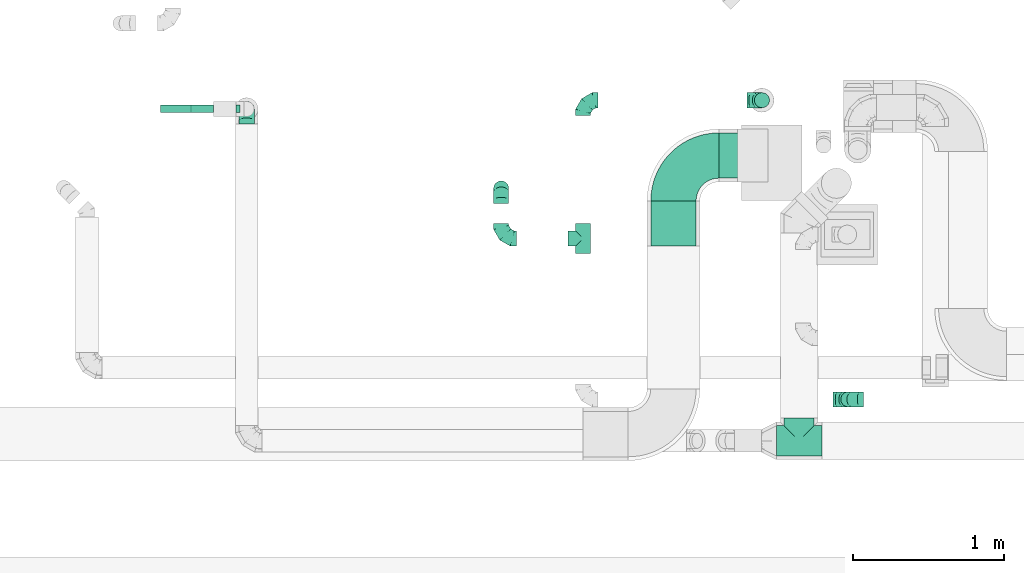
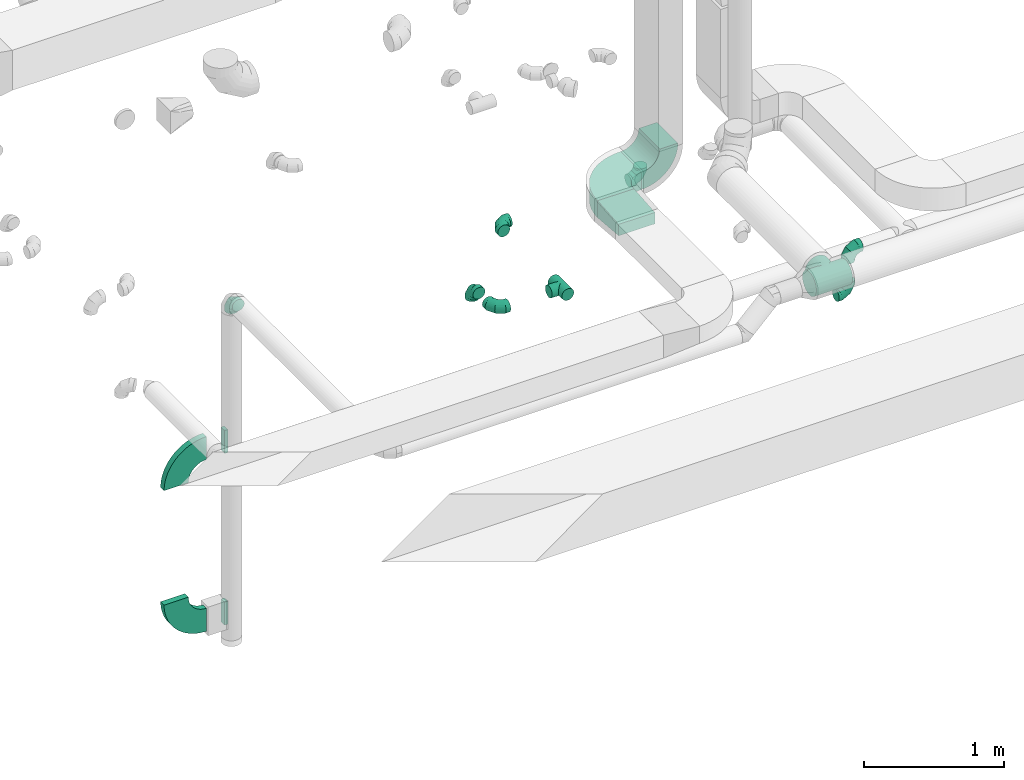
# One storey, part 64 of 97: 16 flow fittings.
"""IFC2X3 building model written with IfcOpenShell, lengths in millimetres."""

from ifc_helpers import new_model, entity, si_unit, converted_unit, derived_unit, direction, frame, frame_2d, origin, origin_2d_with_axis, place, context, subcontext, project, spatial, polyline, circle_curve, parameter, trimmed, segment, composite_curve, rectangle, outline, extrude, faceted_brep, source, transform, mapped, material, type_object, type_shapes, element, save


model = new_model("IFC2X3")

# Units and contexts
model_context = context("Model", 3, precision=0.01, world=origin(), true_north=direction((6.12303176911189e-17, 1.0)))
body_context = subcontext(model_context, "Body", "Model", "MODEL_VIEW")
ifc_project = project(units=[si_unit("LENGTHUNIT", "METRE", prefix="MILLI"), si_unit("AREAUNIT", "SQUARE_METRE"), si_unit("VOLUMEUNIT", "CUBIC_METRE"), converted_unit("PLANEANGLEUNIT", "DEGREE", entity("IfcRatioMeasure", 0.0174532925199433), si_unit("PLANEANGLEUNIT", "RADIAN"), dimensions=[0, 0, 0, 0, 0, 0, 0]), si_unit("MASSUNIT", "GRAM", prefix="KILO"), derived_unit("MASSDENSITYUNIT", [(si_unit("MASSUNIT", "GRAM", prefix="KILO"), 1), (si_unit("LENGTHUNIT", "METRE"), -3)]), derived_unit("MOMENTOFINERTIAUNIT", [(si_unit("LENGTHUNIT", "METRE"), 4)]), si_unit("TIMEUNIT", "SECOND"), si_unit("FREQUENCYUNIT", "HERTZ"), si_unit("THERMODYNAMICTEMPERATUREUNIT", "DEGREE_CELSIUS"), derived_unit("THERMALTRANSMITTANCEUNIT", [(si_unit("MASSUNIT", "GRAM", prefix="KILO"), 1), (si_unit("THERMODYNAMICTEMPERATUREUNIT", "KELVIN"), -1), (si_unit("TIMEUNIT", "SECOND"), -3)]), derived_unit("VOLUMETRICFLOWRATEUNIT", [(si_unit("LENGTHUNIT", "METRE"), 3), (si_unit("TIMEUNIT", "SECOND"), -1)]), derived_unit("MASSFLOWRATEUNIT", [(si_unit("MASSUNIT", "GRAM", prefix="KILO"), 1), (si_unit("TIMEUNIT", "SECOND"), -1)]), derived_unit("ROTATIONALFREQUENCYUNIT", [(si_unit("TIMEUNIT", "SECOND"), -1)]), si_unit("ELECTRICCURRENTUNIT", "AMPERE"), si_unit("ELECTRICVOLTAGEUNIT", "VOLT"), si_unit("POWERUNIT", "WATT"), si_unit("FORCEUNIT", "NEWTON", prefix="KILO"), si_unit("ILLUMINANCEUNIT", "LUX"), si_unit("LUMINOUSFLUXUNIT", "LUMEN"), si_unit("LUMINOUSINTENSITYUNIT", "CANDELA"), derived_unit("USERDEFINED", [(si_unit("MASSUNIT", "GRAM", prefix="KILO"), -1), (si_unit("LENGTHUNIT", "METRE"), -2), (si_unit("TIMEUNIT", "SECOND"), 3), (si_unit("LUMINOUSFLUXUNIT", "LUMEN"), 1)]), derived_unit("LINEARVELOCITYUNIT", [(si_unit("LENGTHUNIT", "METRE"), 1), (si_unit("TIMEUNIT", "SECOND"), -1)]), si_unit("PRESSUREUNIT", "PASCAL"), derived_unit("USERDEFINED", [(si_unit("LENGTHUNIT", "METRE"), -2), (si_unit("MASSUNIT", "GRAM", prefix="KILO"), 1), (si_unit("TIMEUNIT", "SECOND"), -2)]), derived_unit("LINEARFORCEUNIT", [(si_unit("MASSUNIT", "GRAM", prefix="KILO"), 1), (si_unit("LENGTHUNIT", "METRE"), 1), (si_unit("TIMEUNIT", "SECOND"), -2), (si_unit("LENGTHUNIT", "METRE"), -1)]), derived_unit("PLANARFORCEUNIT", [(si_unit("MASSUNIT", "GRAM", prefix="KILO"), 1), (si_unit("LENGTHUNIT", "METRE"), 1), (si_unit("TIMEUNIT", "SECOND"), -2), (si_unit("LENGTHUNIT", "METRE"), -2)])], contexts=[model_context])

# Site, building, storey
site_placement = place(None, origin())
site = spatial("IfcSite", under=ifc_project, at=site_placement, CompositionType="ELEMENT")
building_placement = place(site_placement, origin())
building = spatial("IfcBuilding", under=site, at=building_placement, CompositionType="ELEMENT")
storey_placement = place(building_placement, frame((0.0, 0.0, -4900.0)))
storey = spatial("IfcBuildingStorey", under=building, at=storey_placement, CompositionType="ELEMENT", Elevation=-4900.0)

# Flow fittings
ifc_material = material()
duct_fitting_type_1 = type_object("IfcDuctFittingType", PredefinedType="NOTDEFINED", material=ifc_material)
shared_shape_1 = source(origin(), body_context, "Body", "SweptSolid", [
    extrude(outline(polyline([(-155.71, -62.28), (145.33, -62.28), (153.63, 37.37), (-143.25, 87.2), (-155.71, -62.28)])), frame((150.0, -150.0, 0.0), z_axis=(0.0, 1.0, 0.0), x_axis=(0.996545758244872, 0.0, -0.0830454798538357)), (0.0, 0.0, 1.0), 300.0),
])
type_shapes(duct_fitting_type_1, [shared_shape_1])
flow_fitting_1_placement = place(storey_placement, frame((58329.81, 11187.87, 4325.0), z_axis=(0.0, 0.0, 1.0), x_axis=(0.0, -1.0, 0.0)))
element("IfcFlowFitting", 1, at=flow_fitting_1_placement, inside=storey, type_object=duct_fitting_type_1, material=ifc_material, context=body_context, shape_type="MappedRepresentation", body=[
    mapped(shared_shape_1, transform((0.0, 0.0, 0.0), scale=1.0)),
])
duct_fitting_type_2 = type_object("IfcDuctFittingType", PredefinedType="NOTDEFINED", material=ifc_material)
shared_shape_2 = source(origin(), body_context, "Body", "SweptSolid", [
    extrude(rectangle(XDim=26.3610000000093, YDim=200.0, at=origin_2d_with_axis()), frame((6.82, 0.0, -25.0)), (0.0, 0.0, 1.0), 50.0),
])
type_shapes(duct_fitting_type_2, [shared_shape_2])
for number, where, z_axis, x_axis in (
    (2, (55453.91, 11796.17, 2900.0), (0.0, 1.0, 0.0), (-1.0, 0.0, 0.0)),
    (3, (55453.91, 11796.17, 1400.0), (0.0, 1.0, 0.0), (-1.0, 0.0, 0.0)),
):
    element("IfcFlowFitting", number, at=place(storey_placement, frame(where, z_axis=z_axis, x_axis=x_axis)), inside=storey, type_object=duct_fitting_type_2, material=ifc_material, context=body_context, shape_type="MappedRepresentation", body=[
        mapped(shared_shape_2, transform((0.0, 0.0, 0.0), scale=1.0)),
    ])
duct_fitting_type_3 = type_object("IfcDuctFittingType", PredefinedType="NOTDEFINED", material=ifc_material)
shared_shape_3 = source(origin(), body_context, "Body", "Brep", [
    faceted_brep([(-100.0, 0.0, -50.0), (-100.0, -12.94, -48.3), (-100.0, -25.0, -43.3), (-100.0, -35.36, -35.36), (-100.0, -43.3, -25.0), (-100.0, -48.3, -12.94), (-100.0, -50.0, 0.0), (-100.0, -48.3, 12.94), (-100.0, -43.3, 25.0), (-100.0, -35.36, 35.36), (-100.0, -25.0, 43.3), (-100.0, -12.94, 48.3), (-100.0, 0.0, 50.0), (-100.0, 12.94, 48.3), (-100.0, 25.0, 43.3), (-100.0, 35.36, 35.36), (-100.0, 43.3, 25.0), (-100.0, 48.3, 12.94), (-100.0, 50.0, 0.0), (-100.0, 48.3, -12.94), (-100.0, 43.3, -25.0), (-100.0, 35.36, -35.36), (-100.0, 25.0, -43.3), (-100.0, 12.94, -48.3), (-76.67, 12.94, 48.3), (-79.9, 25.0, 43.3), (-73.21, 0.0, 50.0), (-82.68, 35.36, 35.36), (-86.15, 48.3, 12.94), (-86.6, 50.0, 0.0), (-84.81, 43.3, 25.0), (-84.81, 43.3, -25.0), (-82.68, 35.36, -35.36), (-86.15, 48.3, -12.94), (-76.67, 12.94, -48.3), (-73.21, 0.0, -50.0), (-79.9, 25.0, -43.3), (-69.74, -12.94, -48.3), (-66.51, -25.0, -43.3), (-63.73, -35.36, -35.36), (-61.6, -43.3, -25.0), (-60.26, -48.3, -12.94), (-59.81, -50.0, 0.0), (-60.26, -48.3, 12.94), (-61.6, -43.3, 25.0), (-63.73, -35.36, 35.36), (-66.51, -25.0, 43.3), (-69.74, -12.94, 48.3), (-36.27, 36.27, 48.3), (-45.1, 45.1, 43.3), (-26.79, 26.79, 50.0), (-52.68, 52.68, 35.36), (-58.49, 58.49, 25.0), (-62.15, 62.15, 12.94), (-63.4, 63.4, 0.0), (-62.15, 62.15, -12.94), (-58.49, 58.49, -25.0), (-52.68, 52.68, -35.36), (-36.27, 36.27, -48.3), (-26.79, 26.79, -50.0), (-45.1, 45.1, -43.3), (-17.32, 17.32, -48.3), (-8.49, 8.49, -43.3), (-0.91, 0.91, -35.36), (4.9, -4.9, -25.0), (8.56, -8.56, -12.94), (9.81, -9.81, 0.0), (8.56, -8.56, 12.94), (4.9, -4.9, 25.0), (-0.91, 0.91, 35.36), (-8.49, 8.49, 43.3), (-17.32, 17.32, 48.3), (-12.94, 76.67, 48.3), (-25.0, 79.9, 43.3), (0.0, 73.21, 50.0), (-35.36, 82.68, 35.36), (-43.3, 84.81, 25.0), (-48.3, 86.15, 12.94), (-50.0, 86.6, 0.0), (-48.3, 86.15, -12.94), (-43.3, 84.81, -25.0), (-35.36, 82.68, -35.36), (-12.94, 76.67, -48.3), (0.0, 73.21, -50.0), (-25.0, 79.9, -43.3), (12.94, 69.74, -48.3), (25.0, 66.51, -43.3), (35.36, 63.73, -35.36), (43.3, 61.6, -25.0), (48.3, 60.26, -12.94), (50.0, 59.81, 0.0), (48.3, 60.26, 12.94), (43.3, 61.6, 25.0), (35.36, 63.73, 35.36), (25.0, 66.51, 43.3), (12.94, 69.74, 48.3), (-12.94, 100.0, -48.3), (-25.0, 100.0, -43.3), (-35.36, 100.0, -35.36), (-43.3, 100.0, -25.0), (-48.3, 100.0, -12.94), (-50.0, 100.0, 0.0), (-48.3, 100.0, 12.94), (-43.3, 100.0, 25.0), (-35.36, 100.0, 35.36), (-25.0, 100.0, 43.3), (-12.94, 100.0, 48.3), (0.0, 100.0, 50.0), (12.94, 100.0, 48.3), (25.0, 100.0, 43.3), (35.36, 100.0, 35.36), (43.3, 100.0, 25.0), (48.3, 100.0, 12.94), (50.0, 100.0, 0.0), (48.3, 100.0, -12.94), (43.3, 100.0, -25.0), (35.36, 100.0, -35.36), (25.0, 100.0, -43.3), (12.94, 100.0, -48.3), (0.0, 100.0, -50.0)], [[[0, 1, 2, 3, 4, 5, 6, 7, 8, 9, 10, 11, 12, 13, 14, 15, 16, 17, 18, 19, 20, 21, 22, 23]], [[24, 25, 14, 13]], [[26, 24, 13, 12]], [[14, 25, 27, 15]], [[28, 29, 18, 17]], [[30, 28, 17, 16]], [[15, 27, 30, 16]], [[20, 31, 32, 21]], [[33, 31, 20, 19]], [[18, 29, 33, 19]], [[34, 35, 0, 23]], [[36, 34, 23, 22]], [[32, 36, 22, 21]], [[2, 1, 37, 38]], [[3, 2, 38, 39]], [[0, 35, 37, 1]], [[5, 4, 40, 41]], [[6, 5, 41, 42]], [[3, 39, 40, 4]], [[6, 42, 43, 7]], [[7, 43, 44, 8]], [[8, 44, 45, 9]], [[10, 46, 47, 11]], [[11, 47, 26, 12]], [[10, 9, 45, 46]], [[48, 49, 25, 24]], [[50, 48, 24, 26]], [[27, 25, 49, 51]], [[52, 53, 28, 30]], [[51, 52, 30, 27]], [[29, 28, 53, 54]], [[55, 56, 31, 33]], [[54, 55, 33, 29]], [[57, 32, 31, 56]], [[58, 59, 35, 34]], [[60, 58, 34, 36]], [[57, 60, 36, 32]], [[37, 35, 59, 61]], [[38, 37, 61, 62]], [[39, 38, 62, 63]], [[41, 40, 64, 65]], [[42, 41, 65, 66]], [[63, 64, 40, 39]], [[43, 42, 66, 67]], [[44, 43, 67, 68]], [[68, 69, 45, 44]], [[46, 45, 69, 70]], [[47, 46, 70, 71]], [[26, 47, 71, 50]], [[72, 73, 49, 48]], [[74, 72, 48, 50]], [[51, 49, 73, 75]], [[76, 77, 53, 52]], [[75, 76, 52, 51]], [[54, 53, 77, 78]], [[79, 80, 56, 55]], [[78, 79, 55, 54]], [[81, 57, 56, 80]], [[82, 83, 59, 58]], [[84, 82, 58, 60]], [[81, 84, 60, 57]], [[61, 59, 83, 85]], [[62, 61, 85, 86]], [[63, 62, 86, 87]], [[65, 64, 88, 89]], [[66, 65, 89, 90]], [[87, 88, 64, 63]], [[67, 66, 90, 91]], [[68, 67, 91, 92]], [[92, 93, 69, 68]], [[70, 69, 93, 94]], [[71, 70, 94, 95]], [[50, 71, 95, 74]], [[96, 97, 98, 99, 100, 101, 102, 103, 104, 105, 106, 107, 108, 109, 110, 111, 112, 113, 114, 115, 116, 117, 118, 119]], [[72, 74, 107, 106]], [[73, 72, 106, 105]], [[75, 73, 105, 104]], [[77, 76, 103, 102]], [[78, 77, 102, 101]], [[75, 104, 103, 76]], [[78, 101, 100, 79]], [[79, 100, 99, 80]], [[80, 99, 98, 81]], [[96, 119, 83, 82]], [[97, 96, 82, 84]], [[84, 81, 98, 97]], [[83, 119, 118, 85]], [[85, 118, 117, 86]], [[86, 117, 116, 87]], [[88, 115, 114, 89]], [[89, 114, 113, 90]], [[87, 116, 115, 88]], [[91, 90, 113, 112]], [[92, 91, 112, 111]], [[93, 92, 111, 110]], [[95, 94, 109, 108]], [[74, 95, 108, 107]], [[110, 109, 94, 93]]]),
])
type_shapes(duct_fitting_type_3, [shared_shape_3])
for number, where, z_axis, x_axis in (
    (4, (58915.63, 11854.23, 3950.0), (0.0, -1.0, 0.0), (1.0, 0.0, 0.0)),
    (5, (57731.35, 11854.23, 3950.0), (0.0, 0.0, 1.0), (-1.0, 0.0, 0.0)),
    (6, (57189.28, 10938.3, 3950.0), (0.0, 0.0, 1.0), (0.0, -1.0, 0.0)),
    (7, (57189.28, 11270.06, 3950.0), (-1.0, 0.0, 0.0), (0.0, 1.0, 0.0)),
    (8, (59487.7, 9873.56, 4320.0), (0.0, 1.0, 0.0), (0.0, 0.0, 1.0)),
    (9, (59487.7, 9873.56, 3950.0), (0.0, 1.0, 0.0), (0.0, 0.0, -1.0)),
    (10, (55504.18, 11796.17, 4115.0), (1.0, 0.0, 0.0), (0.0, 0.0, 1.0)),
):
    element("IfcFlowFitting", number, at=place(storey_placement, frame(where, z_axis=z_axis, x_axis=x_axis)), inside=storey, type_object=duct_fitting_type_3, material=ifc_material, context=body_context, shape_type="MappedRepresentation", body=[
        mapped(shared_shape_3, transform((0.0, 0.0, 0.0), scale=1.0)),
    ])
duct_fitting_type_4 = type_object("IfcDuctFittingType", PredefinedType="NOTDEFINED", material=ifc_material)
shared_shape_4 = source(origin(), body_context, "Body", "Brep", [
    faceted_brep([(6.73, -6.73, -49.54), (100.0, 0.0, -50.0), (100.0, -12.94, -48.3), (100.0, -25.0, -43.3), (19.94, -19.94, -45.85), (32.27, -32.27, -38.19), (100.0, -35.36, -35.36), (26.27, -26.27, -42.54), (0.0, 0.0, -50.0), (-6.73, -6.73, -49.54), (-100.0, 0.0, -50.0), (13.4, -13.4, -48.17), (37.8, -37.8, -32.73), (100.0, -43.3, -25.0), (46.54, -46.54, -18.28), (100.0, -48.3, -12.94), (49.1, -49.1, -9.45), (100.0, -50.0, 0.0), (42.66, -42.66, -26.08), (50.0, -50.0, 0.0), (-100.0, -50.0, 0.0), (-49.1, -49.1, -9.45), (-50.0, -50.0, 0.0), (49.1, -49.1, 9.45), (100.0, -48.3, 12.94), (46.54, -46.54, 18.28), (100.0, -43.3, 25.0), (37.8, -37.8, 32.73), (100.0, -35.36, 35.36), (-49.1, -49.1, 9.45), (42.66, -42.66, 26.08), (32.27, -32.27, 38.19), (26.27, -26.27, 42.54), (100.0, -25.0, 43.3), (19.94, -19.94, 45.85), (100.0, -12.94, 48.3), (6.73, -6.73, 49.54), (100.0, 0.0, 50.0), (13.4, -13.4, 48.17), (0.0, 0.0, 50.0), (-6.73, -6.73, 49.54), (-100.0, 0.0, 50.0), (12.94, -100.0, -48.3), (25.0, -100.0, -43.3), (35.36, -100.0, -35.36), (43.3, -100.0, -25.0), (48.3, -100.0, -12.94), (50.0, -100.0, 0.0), (48.3, -100.0, 12.94), (43.3, -100.0, 25.0), (35.36, -100.0, 35.36), (25.0, -100.0, 43.3), (12.94, -100.0, 48.3), (0.0, -100.0, 50.0), (-12.94, -100.0, 48.3), (-25.0, -100.0, 43.3), (-35.36, -100.0, 35.36), (-43.3, -100.0, 25.0), (-48.3, -100.0, 12.94), (-50.0, -100.0, 0.0), (-48.3, -100.0, -12.94), (-43.3, -100.0, -25.0), (-35.36, -100.0, -35.36), (-25.0, -100.0, -43.3), (-12.94, -100.0, -48.3), (0.0, -100.0, -50.0), (-19.94, -19.94, -45.85), (-32.27, -32.27, -38.19), (-26.27, -26.27, -42.54), (-13.4, -13.4, -48.17), (-37.8, -37.8, -32.73), (-46.54, -46.54, -18.28), (-42.66, -42.66, -26.08), (-46.54, -46.54, 18.28), (-37.8, -37.8, 32.73), (-42.66, -42.66, 26.08), (-32.27, -32.27, 38.19), (-26.27, -26.27, 42.54), (-19.94, -19.94, 45.85), (-13.4, -13.4, 48.17), (-100.0, -12.94, -48.3), (-100.0, -25.0, -43.3), (-100.0, -35.36, -35.36), (-100.0, -43.3, -25.0), (-100.0, -48.3, -12.94), (-100.0, -48.3, 12.94), (-100.0, -43.3, 25.0), (-100.0, -35.36, 35.36), (-100.0, -25.0, 43.3), (-100.0, -12.94, 48.3), (-100.0, 12.94, 48.3), (-100.0, 25.0, 43.3), (-100.0, 35.36, 35.36), (-100.0, 43.3, 25.0), (-100.0, 48.3, 12.94), (-100.0, 50.0, 0.0), (-100.0, 48.3, -12.94), (-100.0, 43.3, -25.0), (-100.0, 35.36, -35.36), (-100.0, 25.0, -43.3), (-100.0, 12.94, -48.3), (100.0, 12.94, -48.3), (100.0, 25.0, -43.3), (100.0, 35.36, -35.36), (100.0, 43.3, -25.0), (100.0, 48.3, -12.94), (100.0, 50.0, 0.0), (100.0, 48.3, 12.94), (100.0, 43.3, 25.0), (100.0, 35.36, 35.36), (100.0, 25.0, 43.3), (100.0, 12.94, 48.3)], [[[0, 1, 2]], [[2, 3, 4]], [[5, 3, 6]], [[5, 7, 3]], [[0, 8, 1]], [[8, 9, 10]], [[4, 11, 2]], [[7, 4, 3]], [[0, 2, 11]], [[12, 6, 13]], [[14, 13, 15]], [[16, 15, 17]], [[18, 12, 13]], [[16, 14, 15]], [[19, 16, 17]], [[20, 21, 22]], [[18, 13, 14]], [[6, 12, 5]], [[23, 17, 24]], [[25, 24, 26]], [[27, 26, 28]], [[23, 19, 17]], [[22, 29, 20]], [[30, 25, 26]], [[27, 30, 26]], [[23, 24, 25]], [[28, 31, 27]], [[32, 31, 33]], [[33, 31, 28]], [[34, 33, 35]], [[36, 35, 37]], [[34, 32, 33]], [[36, 38, 35]], [[39, 36, 37]], [[40, 39, 41]], [[34, 35, 38]], [[42, 43, 44, 45, 46, 47, 48, 49, 50, 51, 52, 53, 54, 55, 56, 57, 58, 59, 60, 61, 62, 63, 64, 65]], [[36, 53, 52]], [[52, 51, 34]], [[31, 51, 50]], [[31, 32, 51]], [[36, 39, 53]], [[34, 38, 52]], [[32, 34, 51]], [[36, 52, 38]], [[27, 50, 49]], [[25, 49, 48]], [[23, 48, 47]], [[30, 27, 49]], [[23, 25, 48]], [[19, 23, 47]], [[30, 49, 25]], [[50, 27, 31]], [[47, 46, 16]], [[45, 44, 12]], [[46, 45, 14]], [[16, 19, 47]], [[18, 14, 45]], [[12, 18, 45]], [[16, 46, 14]], [[44, 5, 12]], [[7, 5, 43]], [[43, 5, 44]], [[4, 43, 42]], [[0, 42, 65]], [[4, 7, 43]], [[0, 11, 42]], [[8, 0, 65]], [[4, 42, 11]], [[9, 65, 64]], [[64, 63, 66]], [[67, 63, 62]], [[67, 68, 63]], [[9, 8, 65]], [[66, 69, 64]], [[68, 66, 63]], [[9, 64, 69]], [[70, 62, 61]], [[71, 61, 60]], [[21, 60, 59]], [[72, 70, 61]], [[21, 71, 60]], [[22, 21, 59]], [[72, 61, 71]], [[62, 70, 67]], [[29, 59, 58]], [[73, 58, 57]], [[74, 57, 56]], [[29, 22, 59]], [[75, 73, 57]], [[74, 75, 57]], [[29, 58, 73]], [[56, 76, 74]], [[77, 76, 55]], [[55, 76, 56]], [[78, 55, 54]], [[40, 54, 53]], [[78, 77, 55]], [[40, 79, 54]], [[39, 40, 53]], [[78, 54, 79]], [[10, 80, 81, 82, 83, 84, 20, 85, 86, 87, 88, 89, 41, 90, 91, 92, 93, 94, 95, 96, 97, 98, 99, 100]], [[101, 102, 103, 104, 105, 106, 107, 108, 109, 110, 111, 37, 35, 33, 28, 26, 24, 17, 15, 13, 6, 3, 2, 1]], [[39, 37, 111, 90, 41]], [[91, 90, 111, 110]], [[110, 109, 92, 91]], [[93, 92, 109, 108]], [[94, 93, 108, 107]], [[95, 94, 107, 106]], [[105, 104, 97, 96]], [[106, 105, 96, 95]], [[104, 103, 98, 97]], [[99, 98, 103, 102]], [[100, 99, 102, 101]], [[8, 10, 100, 101, 1]], [[69, 66, 80]], [[9, 69, 80]], [[10, 9, 80]], [[81, 68, 67]], [[81, 80, 66]], [[81, 67, 82]], [[68, 81, 66]], [[70, 72, 83]], [[71, 21, 84]], [[72, 71, 83]], [[82, 70, 83]], [[21, 20, 84]], [[84, 83, 71]], [[70, 82, 67]], [[29, 73, 85]], [[75, 74, 86]], [[73, 75, 86]], [[85, 20, 29]], [[73, 86, 85]], [[74, 87, 86]], [[74, 76, 87]], [[78, 79, 89]], [[79, 40, 89]], [[76, 77, 88]], [[78, 88, 77]], [[78, 89, 88]], [[40, 41, 89]], [[76, 88, 87]]]),
])
type_shapes(duct_fitting_type_4, [shared_shape_4])
flow_fitting_2_placement = place(storey_placement, frame((57731.35, 10938.3, 3950.0), z_axis=(0.0, 0.0, 1.0), x_axis=(0.0, -1.0, 0.0)))
element("IfcFlowFitting", 11, at=flow_fitting_2_placement, inside=storey, type_object=duct_fitting_type_4, material=ifc_material, context=body_context, shape_type="MappedRepresentation", body=[
    mapped(shared_shape_4, transform((0.0, 0.0, 0.0), scale=1.0)),
])
duct_fitting_type_5 = type_object("IfcDuctFittingType", PredefinedType="NOTDEFINED", material=ifc_material)
shared_shape_5 = source(origin(), body_context, "Body", "Brep", [
    faceted_brep([(14.97, -14.97, -98.87), (150.0, 0.0, -100.0), (150.0, -25.88, -96.59), (150.0, -50.0, -86.6), (44.19, -44.19, -89.71), (58.0, -58.0, -81.46), (150.0, -70.71, -70.71), (0.0, 0.0, -100.0), (-14.97, -14.97, -98.87), (-150.0, 0.0, -100.0), (29.76, -29.76, -95.47), (82.28, -82.28, -56.83), (150.0, -86.6, -50.0), (91.56, -91.56, -40.2), (150.0, -96.59, -25.88), (97.79, -97.79, -20.93), (150.0, -100.0, 0.0), (70.86, -70.86, -70.56), (100.0, -100.0, 0.0), (-150.0, -100.0, 0.0), (-97.79, -97.79, -20.93), (-100.0, -100.0, 0.0), (97.79, -97.79, 20.93), (-97.79, -97.79, 20.93), (150.0, -96.59, 25.88), (91.56, -91.56, 40.2), (150.0, -86.6, 50.0), (150.0, -70.71, 70.71), (70.86, -70.86, 70.56), (82.28, -82.28, 56.83), (58.0, -58.0, 81.46), (150.0, -50.0, 86.6), (44.19, -44.19, 89.71), (150.0, -25.88, 96.59), (14.97, -14.97, 98.87), (150.0, 0.0, 100.0), (29.76, -29.76, 95.47), (0.0, 0.0, 100.0), (-14.97, -14.97, 98.87), (-150.0, 0.0, 100.0), (25.88, -150.0, -96.59), (50.0, -150.0, -86.6), (70.71, -150.0, -70.71), (86.6, -150.0, -50.0), (96.59, -150.0, -25.88), (100.0, -150.0, 0.0), (96.59, -150.0, 25.88), (86.6, -150.0, 50.0), (70.71, -150.0, 70.71), (50.0, -150.0, 86.6), (25.88, -150.0, 96.59), (0.0, -150.0, 100.0), (-25.88, -150.0, 96.59), (-50.0, -150.0, 86.6), (-70.71, -150.0, 70.71), (-86.6, -150.0, 50.0), (-96.59, -150.0, 25.88), (-100.0, -150.0, 0.0), (-96.59, -150.0, -25.88), (-86.6, -150.0, -50.0), (-70.71, -150.0, -70.71), (-50.0, -150.0, -86.6), (-25.88, -150.0, -96.59), (0.0, -150.0, -100.0), (-44.19, -44.19, -89.71), (-58.0, -58.0, -81.46), (-29.76, -29.76, -95.47), (-82.28, -82.28, -56.83), (-91.56, -91.56, -40.2), (-70.86, -70.86, -70.56), (-91.56, -91.56, 40.2), (-70.86, -70.86, 70.56), (-82.28, -82.28, 56.83), (-58.0, -58.0, 81.46), (-44.19, -44.19, 89.71), (-29.76, -29.76, 95.47), (-150.0, -25.88, -96.59), (-150.0, -50.0, -86.6), (-150.0, -70.71, -70.71), (-150.0, -86.6, -50.0), (-150.0, -96.59, -25.88), (-150.0, -96.59, 25.88), (-150.0, -86.6, 50.0), (-150.0, -70.71, 70.71), (-150.0, -50.0, 86.6), (-150.0, -25.88, 96.59), (-150.0, 25.88, 96.59), (-150.0, 50.0, 86.6), (-150.0, 70.71, 70.71), (-150.0, 86.6, 50.0), (-150.0, 96.59, 25.88), (-150.0, 100.0, 0.0), (-150.0, 96.59, -25.88), (-150.0, 86.6, -50.0), (-150.0, 70.71, -70.71), (-150.0, 50.0, -86.6), (-150.0, 25.88, -96.59), (150.0, 25.88, -96.59), (150.0, 50.0, -86.6), (150.0, 70.71, -70.71), (150.0, 86.6, -50.0), (150.0, 96.59, -25.88), (150.0, 100.0, 0.0), (150.0, 96.59, 25.88), (150.0, 86.6, 50.0), (150.0, 70.71, 70.71), (150.0, 50.0, 86.6), (150.0, 25.88, 96.59)], [[[0, 1, 2]], [[2, 3, 4]], [[5, 3, 6]], [[5, 4, 3]], [[0, 7, 1]], [[7, 8, 9]], [[4, 10, 2]], [[0, 2, 10]], [[11, 6, 12]], [[13, 12, 14]], [[15, 14, 16]], [[11, 17, 6]], [[15, 13, 14]], [[18, 15, 16]], [[19, 20, 21]], [[11, 12, 13]], [[6, 17, 5]], [[22, 18, 16]], [[21, 23, 19]], [[22, 16, 24]], [[25, 24, 26]], [[25, 22, 24]], [[27, 28, 29]], [[25, 26, 29]], [[29, 26, 27]], [[30, 27, 31]], [[32, 31, 33]], [[34, 33, 35]], [[32, 30, 31]], [[34, 36, 33]], [[37, 34, 35]], [[38, 37, 39]], [[32, 33, 36]], [[27, 30, 28]], [[40, 41, 42, 43, 44, 45, 46, 47, 48, 49, 50, 51, 52, 53, 54, 55, 56, 57, 58, 59, 60, 61, 62, 63]], [[34, 51, 50]], [[50, 49, 32]], [[30, 49, 48]], [[30, 32, 49]], [[34, 37, 51]], [[32, 36, 50]], [[34, 50, 36]], [[29, 48, 47]], [[25, 47, 46]], [[22, 46, 45]], [[29, 28, 48]], [[22, 25, 46]], [[18, 22, 45]], [[29, 47, 25]], [[48, 28, 30]], [[15, 18, 45]], [[15, 45, 44]], [[13, 44, 43]], [[13, 15, 44]], [[42, 17, 11]], [[13, 43, 11]], [[11, 43, 42]], [[5, 42, 41]], [[4, 41, 40]], [[0, 40, 63]], [[4, 5, 41]], [[0, 10, 40]], [[7, 0, 63]], [[4, 40, 10]], [[42, 5, 17]], [[8, 63, 62]], [[62, 61, 64]], [[65, 61, 60]], [[65, 64, 61]], [[8, 7, 63]], [[64, 66, 62]], [[8, 62, 66]], [[67, 60, 59]], [[68, 59, 58]], [[20, 58, 57]], [[67, 69, 60]], [[20, 68, 58]], [[21, 20, 57]], [[67, 59, 68]], [[60, 69, 65]], [[23, 21, 57]], [[23, 57, 56]], [[70, 56, 55]], [[70, 23, 56]], [[54, 71, 72]], [[70, 55, 72]], [[72, 55, 54]], [[73, 54, 53]], [[74, 53, 52]], [[38, 52, 51]], [[74, 73, 53]], [[38, 75, 52]], [[37, 38, 51]], [[74, 52, 75]], [[54, 73, 71]], [[9, 76, 77, 78, 79, 80, 19, 81, 82, 83, 84, 85, 39, 86, 87, 88, 89, 90, 91, 92, 93, 94, 95, 96]], [[97, 98, 99, 100, 101, 102, 103, 104, 105, 106, 107, 35, 33, 31, 27, 26, 24, 16, 14, 12, 6, 3, 2, 1]], [[37, 35, 107, 86, 39]], [[87, 86, 107, 106]], [[106, 105, 88, 87]], [[89, 88, 105, 104]], [[90, 89, 104, 103]], [[91, 90, 103, 102]], [[92, 91, 102, 101]], [[93, 92, 101, 100]], [[100, 99, 94, 93]], [[95, 94, 99, 98]], [[96, 95, 98, 97]], [[7, 9, 96, 97, 1]], [[66, 64, 76]], [[8, 66, 76]], [[9, 8, 76]], [[77, 65, 78]], [[77, 76, 64]], [[65, 77, 64]], [[69, 67, 78]], [[68, 20, 80]], [[67, 68, 79]], [[78, 67, 79]], [[20, 19, 80]], [[80, 79, 68]], [[69, 78, 65]], [[23, 70, 81]], [[82, 72, 83]], [[70, 72, 82]], [[19, 23, 81]], [[70, 82, 81]], [[72, 71, 83]], [[74, 75, 85]], [[75, 38, 85]], [[83, 73, 84]], [[73, 83, 71]], [[74, 84, 73]], [[74, 85, 84]], [[38, 39, 85]]]),
])
type_shapes(duct_fitting_type_5, [shared_shape_5])
flow_fitting_3_placement = place(storey_placement, frame((59162.01, 9598.98, 4350.0), z_axis=(0.0, 0.0, 1.0), x_axis=(-1.0, 0.0, 0.0)))
element("IfcFlowFitting", 12, at=flow_fitting_3_placement, inside=storey, type_object=duct_fitting_type_5, material=ifc_material, context=body_context, shape_type="MappedRepresentation", body=[
    mapped(shared_shape_5, transform((0.0, 0.0, 0.0), scale=1.0)),
])
duct_fitting_type_6 = type_object("IfcDuctFittingType", PredefinedType="NOTDEFINED", material=ifc_material)
shared_shape_6 = source(origin(), body_context, "Body", "SweptSolid", [
    extrude(outline(composite_curve([segment(polyline([(-300.0, -150.0), (0.0, -150.0)]), True, "CONTINUOUS"), segment(trimmed(circle_curve(frame_2d((150.0, -150.0), x_axis=(0.0, 1.0)), 150.0), [parameter(0.0)], [parameter(90.0)], True, "PARAMETER"), False, "CONTINUOUS"), segment(polyline([(150.0, 0.0), (150.0, 300.0)]), True, "CONTINUOUS"), segment(trimmed(circle_curve(frame_2d((150.0, -150.0), x_axis=(0.0, 1.0)), 450.0), [parameter(0.0)], [parameter(90.0000000000001)], True, "PARAMETER"), True, "CONTINUOUS")], self_intersect=False)), frame((-150.0, 150.0, -75.0), z_axis=(0.0, 0.0, 1.0), x_axis=(-1.0, 0.0, 0.0)), (0.0, 0.0, 1.0), 150.0),
])
type_shapes(duct_fitting_type_6, [shared_shape_6])
flow_fitting_4_placement = place(storey_placement, frame((58329.81, 11487.87, 4325.0), z_axis=(0.0, 0.0, 1.0), x_axis=(-1.0, 0.0, 0.0)))
element("IfcFlowFitting", 13, at=flow_fitting_4_placement, inside=storey, type_object=duct_fitting_type_6, material=ifc_material, context=body_context, shape_type="MappedRepresentation", body=[
    mapped(shared_shape_6, transform((0.0, 0.0, 0.0), scale=1.0)),
])
duct_fitting_type_7 = type_object("IfcDuctFittingType", PredefinedType="NOTDEFINED", material=ifc_material)
shared_shape_7 = source(origin(), body_context, "Body", "SweptSolid", [
    extrude(outline(composite_curve([segment(polyline([(-187.5, -112.5), (-37.5, -112.5)]), True, "CONTINUOUS"), segment(trimmed(circle_curve(frame_2d((112.5, -112.5), x_axis=(0.0, 1.0)), 150.0), [parameter(0.0)], [parameter(90.0000000000001)], True, "PARAMETER"), False, "CONTINUOUS"), segment(polyline([(112.5, 37.5), (112.5, 187.5)]), True, "CONTINUOUS"), segment(trimmed(circle_curve(frame_2d((112.5, -112.5), x_axis=(0.0, 1.0)), 300.0), [parameter(0.0)], [parameter(90.0000000000001)], True, "PARAMETER"), True, "CONTINUOUS")], self_intersect=False)), frame((-112.5, 112.5, -150.0), z_axis=(0.0, 0.0, 1.0), x_axis=(-1.0, 0.0, 0.0)), (0.0, 0.0, 1.0), 300.0),
])
type_shapes(duct_fitting_type_7, [shared_shape_7])
flow_fitting_5_placement = place(storey_placement, frame((58854.81, 11487.87, 4325.0), z_axis=(0.0, -1.0, 0.0), x_axis=(1.0, 0.0, 0.0)))
element("IfcFlowFitting", 14, at=flow_fitting_5_placement, inside=storey, type_object=duct_fitting_type_7, material=ifc_material, context=body_context, shape_type="MappedRepresentation", body=[
    mapped(shared_shape_7, transform((0.0, 0.0, 0.0), scale=1.0)),
])
duct_fitting_type_8 = type_object("IfcDuctFittingType", PredefinedType="NOTDEFINED", material=ifc_material)
shared_shape_8 = source(origin(), body_context, "Body", "SweptSolid", [
    extrude(outline(composite_curve([segment(polyline([(-225.0, -125.0), (-25.0, -125.0)]), True, "CONTINUOUS"), segment(trimmed(circle_curve(frame_2d((125.0, -125.0), x_axis=(0.0, 1.0)), 150.0), [parameter(0.0)], [parameter(90.0000000000001)], True, "PARAMETER"), False, "CONTINUOUS"), segment(polyline([(125.0, 25.0), (125.0, 225.0)]), True, "CONTINUOUS"), segment(trimmed(circle_curve(frame_2d((125.0, -125.0), x_axis=(0.0, 1.0)), 350.0), [parameter(0.0)], [parameter(90.0000000000001)], True, "PARAMETER"), True, "CONTINUOUS")], self_intersect=False)), frame((-125.0, 125.0, -25.0), z_axis=(0.0, 0.0, 1.0), x_axis=(-1.0, 0.0, 0.0)), (0.0, 0.0, 1.0), 50.0),
])
type_shapes(duct_fitting_type_8, [shared_shape_8])
for number, where, z_axis, x_axis in (
    (15, (55033.91, 11796.17, 2900.0), (0.0, -1.0, 0.0), (-1.0, 0.0, 0.0)),
    (16, (55033.91, 11796.17, 1400.0), (0.0, -1.0, 0.0), (0.0, 0.0, -1.0)),
):
    element("IfcFlowFitting", number, at=place(storey_placement, frame(where, z_axis=z_axis, x_axis=x_axis)), inside=storey, type_object=duct_fitting_type_8, material=ifc_material, context=body_context, shape_type="MappedRepresentation", body=[
        mapped(shared_shape_8, transform((0.0, 0.0, 0.0), scale=1.0)),
    ])

save(model, "model.ifc")
